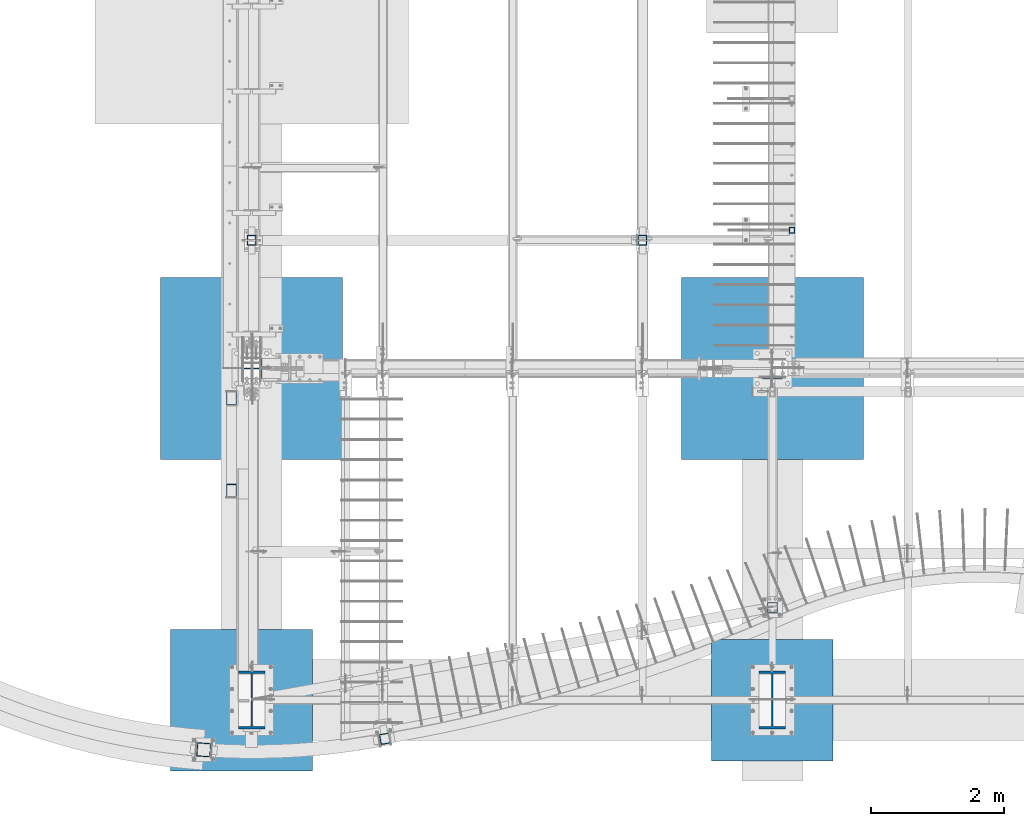
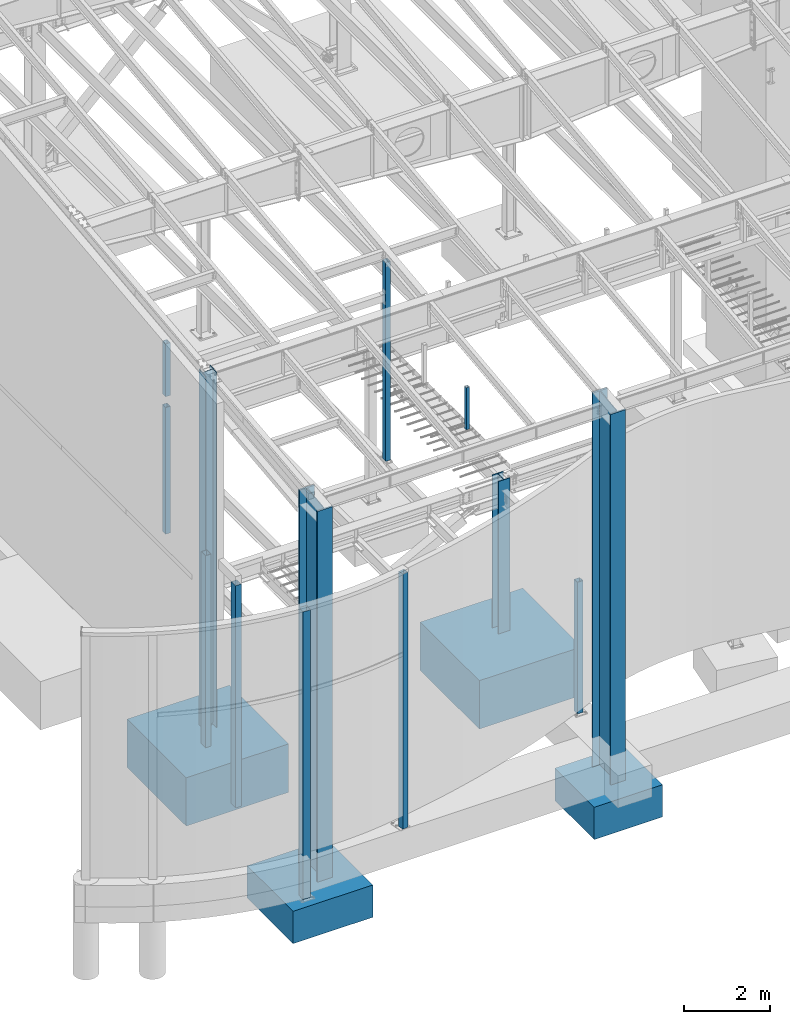
# One storey, part 351 of 1179: 17 columns, 17 elements without a shape of their own.
"""IFC2X3 building model written with IfcOpenShell, lengths in millimetres."""

from ifc_helpers import new_model, si_unit, frame, origin_with_axes, place, context, subcontext, project, spatial, faceted_brep, material, type_object, element, aggregate, save


model = new_model("IFC2X3")

# Units and contexts
model_context = context("Model", 3, precision=1e-05, world=origin_with_axes())
body_context = subcontext(model_context, "Body", "Model", "MODEL_VIEW")
ifc_project = project(units=[si_unit("LENGTHUNIT", "METRE", prefix="MILLI"), si_unit("AREAUNIT", "SQUARE_METRE"), si_unit("VOLUMEUNIT", "CUBIC_METRE"), si_unit("MASSUNIT", "GRAM", prefix="KILO"), si_unit("TIMEUNIT", "SECOND"), si_unit("PLANEANGLEUNIT", "RADIAN"), si_unit("SOLIDANGLEUNIT", "STERADIAN"), si_unit("THERMODYNAMICTEMPERATUREUNIT", "DEGREE_CELSIUS"), si_unit("LUMINOUSINTENSITYUNIT", "LUMEN")], contexts=[model_context])

# Site, building, storey
site_placement = place(None, origin_with_axes())
site = spatial("IfcSite", under=ifc_project, at=site_placement, CompositionType="ELEMENT")
building_placement = place(site_placement, origin_with_axes())
building = spatial("IfcBuilding", under=site, at=building_placement, Name="Undefined", CompositionType="ELEMENT")
storey_placement = place(building_placement, origin_with_axes())
storey = spatial("IfcBuildingStorey", under=building, at=storey_placement, Name="Undefined", CompositionType="ELEMENT", Elevation=0.0)

# Assembly, column
assembly_1_placement = place(storey_placement, origin_with_axes())
assembly_1 = element("IfcElementAssembly", 1, at=assembly_1_placement, inside=storey, Name="COLUMN", AssemblyPlace="NOTDEFINED", PredefinedType="RIGID_FRAME")
ifc_material_1 = material()
column_type_1 = type_object("IfcColumnType", Name="HSS6X6X3/8", PredefinedType="NOTDEFINED")
column_1_placement = place(assembly_1_placement, frame((8280.4000000008, 1835.06494231478, -431.8), z_axis=(0.0, 1.0, 0.0), x_axis=(0.0, 0.0, 1.0)))
column_1 = element("IfcColumn", 2, at=column_1_placement, type_object=column_type_1, material=ifc_material_1, Name="COLUMN", ObjectType="HSS6X6X3/8", context=body_context, shape_type="Brep", body=[
    faceted_brep([(76.2000000000008, 66.675000000112, -66.6749999999902), (76.2000000000008, -66.6750000001084, -66.6750000000175), (3803.64999993333, -66.6749999999993, -66.67500000004), (3803.64999993333, 66.6749999999993, -66.67500000004), (76.2000000000008, -66.6750000001011, 66.674999999992), (3803.65000006668, -66.6749999999993, 66.6749999999599), (76.2000000000008, 66.6750000001193, 66.6750000000193), (3803.65000006668, 66.6749999999993, 66.6749999999599), (76.2000000000008, 76.2000000001281, -76.1999999999898), (76.2000000000008, 76.2000000001317, 76.2000000000216), (3803.6500000762, 76.2000000000007, 76.19999999996), (3803.6499999238, 76.2000000000007, -76.2000000000401), (76.2000000000008, -76.2000000001171, 76.1999999999916), (3803.6500000762, -76.2000000000007, 76.19999999996), (76.2000000000008, -76.2000000001208, -76.2000000000198), (3803.6499999238, -76.2000000000007, -76.2000000000401)], [[[0, 1, 2, 3]], [[1, 4, 5, 2]], [[4, 6, 7, 5]], [[6, 0, 3, 7]], [[8, 9, 10, 11]], [[9, 12, 13, 10]], [[12, 14, 15, 13]], [[14, 8, 11, 15]], [[13, 15, 11, 10], [5, 7, 3, 2]], [[14, 12, 9, 8], [6, 4, 1, 0]]]),
])
aggregate(assembly_1, [column_1])

assembly_2_placement = place(storey_placement, origin_with_axes())
assembly_2 = element("IfcElementAssembly", 3, at=assembly_2_placement, inside=storey, Name="COLUMN", AssemblyPlace="NOTDEFINED", PredefinedType="RIGID_FRAME")
column_type_2 = type_object("IfcColumnType", Name="HSS6X5X5/16", PredefinedType="NOTDEFINED")
column_2_placement = place(assembly_2_placement, frame((432.344791494267, 7366.0, 8013.7), z_axis=(0.0, 1.0, 0.0), x_axis=(0.0, 0.0, 1.0)))
column_2 = element("IfcColumn", 4, at=column_2_placement, type_object=column_type_2, material=ifc_material_1, Name="COLUMN", ObjectType="HSS6X5X5/16", context=body_context, shape_type="Brep", body=[
    faceted_brep([(0.0, 55.5625, -68.2624999999998), (0.0, -55.5625, -68.2624999999998), (1494.56160031085, -55.5625, -68.2624999999998), (1494.56160031085, 55.5625, -68.2624999999998), (0.0, -55.5625, 68.2624999999998), (1494.56160031085, -55.5625, 68.2624999999998), (0.0, 55.5625, 68.2624999999998), (1494.56160031085, 55.5625, 68.2624999999998), (0.0, 63.5, -76.1999999999998), (0.0, 63.5, 76.1999999999998), (1494.56160031085, 63.5, 76.1999999999998), (1494.56160031085, 63.5, -76.1999999999998), (0.0, -63.5, 76.1999999999998), (1494.56160031085, -63.5, 76.1999999999998), (0.0, -63.5, -76.1999999999998), (1494.56160031085, -63.5, -76.1999999999998)], [[[0, 1, 2, 3]], [[1, 4, 5, 2]], [[4, 6, 7, 5]], [[6, 0, 3, 7]], [[8, 9, 10, 11]], [[9, 12, 13, 10]], [[12, 14, 15, 13]], [[14, 8, 11, 15]], [[13, 15, 11, 10], [5, 7, 3, 2]], [[14, 12, 9, 8], [6, 4, 1, 0]]]),
])
aggregate(assembly_2, [column_2])

assembly_3_placement = place(storey_placement, origin_with_axes())
assembly_3 = element("IfcElementAssembly", 5, at=assembly_3_placement, inside=storey, Name="COLUMN", AssemblyPlace="NOTDEFINED", PredefinedType="RIGID_FRAME")
column_3_placement = place(assembly_3_placement, frame((6324.59996446262, 7366.0, 4102.1), z_axis=(0.0, 1.0, 0.0), x_axis=(0.0, 0.0, 1.0)))
column_3 = element("IfcColumn", 6, at=column_3_placement, type_object=column_type_2, material=ifc_material_1, Name="COLUMN", ObjectType="HSS6X5X5/16", context=body_context, shape_type="Brep", body=[
    faceted_brep([(19.0500000000002, 55.5625, -68.2624999999998), (19.0500000000002, -55.5625, -68.2624999999998), (5645.80205145567, -55.5625, -68.2624999999998), (5645.80205145567, 55.5625, -68.2624999999998), (19.0500000000002, -55.5625, 68.2624999999998), (5645.80205145567, -55.5625, 68.2624999999998), (19.0500000000002, 55.5625, 68.2624999999998), (5645.80205145567, 55.5625, 68.2624999999998), (19.0500000000002, 63.5, -76.1999999999998), (19.0500000000002, 63.5, 76.1999999999998), (5645.80205145567, 63.5, 76.1999999999998), (5645.80205145567, 63.5, -76.1999999999998), (19.0500000000002, -63.5, 76.1999999999998), (5645.80205145567, -63.5, 76.1999999999998), (19.0500000000002, -63.5, -76.1999999999998), (5645.80205145567, -63.5, -76.1999999999998)], [[[0, 1, 2, 3]], [[1, 4, 5, 2]], [[4, 6, 7, 5]], [[6, 0, 3, 7]], [[8, 9, 10, 11]], [[9, 12, 13, 10]], [[12, 14, 15, 13]], [[14, 8, 11, 15]], [[13, 15, 11, 10], [5, 7, 3, 2]], [[14, 12, 9, 8], [6, 4, 1, 0]]]),
])
aggregate(assembly_3, [column_3])

assembly_4_placement = place(storey_placement, origin_with_axes())
assembly_4 = element("IfcElementAssembly", 7, at=assembly_4_placement, inside=storey, Name="COLUMN", AssemblyPlace="NOTDEFINED", PredefinedType="RIGID_FRAME")
column_4_placement = place(assembly_4_placement, frame((432.344791494267, 7366.0, 4102.1), z_axis=(0.0, 1.0, 0.0), x_axis=(0.0, 0.0, 1.0)))
column_4 = element("IfcColumn", 8, at=column_4_placement, type_object=column_type_2, material=ifc_material_1, Name="COLUMN", ObjectType="HSS6X5X5/16", context=body_context, shape_type="Brep", body=[
    faceted_brep([(19.0500000000002, 55.5625, -68.2624999999998), (19.0500000000002, -55.5625, -68.2624999999998), (3606.8, -55.5625, -68.2624999999998), (3606.8, 55.5625, -68.2624999999998), (19.0500000000002, -55.5625, 68.2624999999998), (3606.8, -55.5625, 68.2624999999998), (19.0500000000002, 55.5625, 68.2624999999998), (3606.8, 55.5625, 68.2624999999998), (19.0500000000002, 63.5, -76.1999999999998), (19.0500000000002, 63.5, 76.1999999999998), (3606.8, 63.5, 76.1999999999998), (3606.8, 63.5, -76.1999999999998), (19.0500000000002, -63.5, 76.1999999999998), (3606.8, -63.5, 76.1999999999998), (19.0500000000002, -63.5, -76.1999999999998), (3606.8, -63.5, -76.1999999999998)], [[[0, 1, 2, 3]], [[1, 4, 5, 2]], [[4, 6, 7, 5]], [[6, 0, 3, 7]], [[8, 9, 10, 11]], [[9, 12, 13, 10]], [[12, 14, 15, 13]], [[14, 8, 11, 15]], [[13, 15, 11, 10], [5, 7, 3, 2]], [[14, 12, 9, 8], [6, 4, 1, 0]]]),
])
aggregate(assembly_4, [column_4])

assembly_5_placement = place(storey_placement, origin_with_axes())
assembly_5 = element("IfcElementAssembly", 9, at=assembly_5_placement, inside=storey, Name="COLUMN", AssemblyPlace="NOTDEFINED", PredefinedType="RIGID_FRAME")
column_type_3 = type_object("IfcColumnType", Name="HSS6X6X1/4", PredefinedType="NOTDEFINED")
column_5_placement = place(assembly_5_placement, frame((2444.75, -144.4625, -431.8), z_axis=(-0.169391131050126, 0.985548905291645, 0.0), x_axis=(0.0, 0.0, 1.0)))
column_5 = element("IfcColumn", 10, at=column_5_placement, type_object=column_type_3, material=ifc_material_1, Name="COLUMN", ObjectType="HSS6X6X1/4", context=body_context, shape_type="Brep", body=[
    faceted_brep([(57.15, 69.8499999999804, -69.8499999999957), (57.15, -69.8500000000104, -69.8499999999983), (7283.45, -69.8500000000104, -69.8499999999983), (7283.45, 69.8499999999804, -69.8499999999957), (57.15, -69.8499999999808, 69.8499999999956), (7283.45, -69.8499999999808, 69.8499999999956), (57.15, 69.8500000000104, 69.8499999999981), (7283.45, 69.8500000000104, 69.8499999999981), (57.15, 76.1999999999789, -76.1999999999953), (57.15, 76.2000000000112, 76.1999999999979), (7283.45, 76.2000000000112, 76.1999999999979), (7283.45, 76.1999999999789, -76.1999999999953), (57.15, -76.1999999999789, 76.1999999999952), (7283.45, -76.1999999999789, 76.1999999999952), (57.15, -76.2000000000116, -76.199999999998), (7283.45, -76.2000000000116, -76.199999999998)], [[[0, 1, 2, 3]], [[1, 4, 5, 2]], [[4, 6, 7, 5]], [[6, 0, 3, 7]], [[8, 9, 10, 11]], [[9, 12, 13, 10]], [[12, 14, 15, 13]], [[14, 8, 11, 15]], [[13, 15, 11, 10], [5, 7, 3, 2]], [[14, 12, 9, 8], [6, 4, 1, 0]]]),
])
aggregate(assembly_5, [column_5])

assembly_6_placement = place(storey_placement, origin_with_axes())
assembly_6 = element("IfcElementAssembly", 11, at=assembly_6_placement, inside=storey, Name="COLUMN", AssemblyPlace="NOTDEFINED", PredefinedType="RIGID_FRAME")
column_type_4 = type_object("IfcColumnType", Name="HSS3-1/2X3-1/2X5/16", PredefinedType="NOTDEFINED")
column_6_placement = place(assembly_6_placement, frame((8575.675, 7518.40000000001, 4108.45), z_axis=(0.0, 1.0, 0.0), x_axis=(0.0, 0.0, 1.0)))
column_6 = element("IfcColumn", 12, at=column_6_placement, type_object=column_type_4, material=ifc_material_1, Name="COLUMN", ObjectType="HSS3-1/2X3-1/2X5/16", context=body_context, shape_type="Brep", body=[
    faceted_brep([(0.0, 36.5125000000007, -36.5125000000007), (0.0, -36.5125000000007, -36.5125000000007), (1189.03749999998, -36.5125000000007, -36.5124999999998), (1189.03749999998, 36.5125000000007, -36.5124999999998), (0.0, -36.5125000000007, 36.5125000000007), (1189.03749999998, -36.5125000000007, 36.5124999999998), (0.0, 36.5125000000007, 36.5125000000007), (1189.03749999998, 36.5125000000007, 36.5124999999998), (0.0, 44.4500000000007, -44.4499999999998), (0.0, 44.4500000000007, 44.4500000000007), (1189.03749999998, 44.4500000000007, 44.4499999999998), (1189.03749999998, 44.4500000000007, -44.4499999999998), (0.0, -44.4500000000007, 44.4500000000007), (1189.03749999998, -44.4500000000007, 44.4499999999998), (0.0, -44.4500000000007, -44.4500000000007), (1189.03749999998, -44.4500000000007, -44.4499999999998)], [[[0, 1, 2, 3]], [[1, 4, 5, 2]], [[4, 6, 7, 5]], [[6, 0, 3, 7]], [[8, 9, 10, 11]], [[9, 12, 13, 10]], [[12, 14, 15, 13]], [[14, 8, 11, 15]], [[13, 15, 11, 10], [5, 7, 3, 2]], [[14, 12, 9, 8], [6, 4, 1, 0]]]),
])
aggregate(assembly_6, [column_6])

assembly_7_placement = place(storey_placement, origin_with_axes())
assembly_7 = element("IfcElementAssembly", 13, at=assembly_7_placement, inside=storey, Name="COLUMN", AssemblyPlace="NOTDEFINED", PredefinedType="RIGID_FRAME")
column_type_5 = type_object("IfcColumnType", Name="HSS8X6X3/8", PredefinedType="NOTDEFINED")
column_7_placement = place(assembly_7_placement, frame((127.0, 3590.925, -1219.2), z_axis=(0.0, 1.0, 0.0), x_axis=(0.0, 0.0, 1.0)))
column_7 = element("IfcColumn", 14, at=column_7_placement, type_object=column_type_5, material=ifc_material_1, Name="COLUMN", ObjectType="HSS8X6X3/8", context=body_context, shape_type="Brep", body=[
    faceted_brep([(9.52500000000009, -66.67500038147, -101.6), (19.0499996185301, -76.2, -101.6), (19.0499996185301, -76.2, 101.6), (9.52500000000009, -66.67500038147, 101.6), (9.52500000002851, 66.6750000000029, -92.0750000000025), (9.52500000002851, -66.6750000000029, -92.0750000000025), (6299.2, -66.675, -92.0749999999998), (6299.2, 66.675, -92.0749999999998), (9.52499999997079, -66.6750000000029, 92.074999999998), (6299.2, -66.675, 92.0749999999998), (9.52499999997079, 66.6750000000029, 92.074999999998), (6299.2, 66.675, 92.0749999999998), (9.52500000003153, 76.1999999999971, -101.600000000002), (9.52499999996778, 76.1999999999971, 101.599999999998), (6299.2, 76.2, 101.6), (6299.2, 76.2, -101.6), (6299.2, -76.2, 101.6), (6299.2, -76.2, -101.6)], [[[0, 1, 2, 3]], [[4, 5, 6, 7]], [[5, 8, 9, 6]], [[8, 10, 11, 9]], [[10, 4, 7, 11]], [[12, 13, 14, 15]], [[16, 14, 13, 3, 2]], [[17, 16, 2, 1]], [[12, 15, 17, 1, 0]], [[16, 17, 15, 14], [9, 11, 7, 6]], [[13, 12, 0, 3], [10, 8, 5, 4]]]),
])
aggregate(assembly_7, [column_7])

assembly_8_placement = place(storey_placement, origin_with_axes())
assembly_8 = element("IfcElementAssembly", 15, at=assembly_8_placement, inside=storey, Name="COLUMN", AssemblyPlace="NOTDEFINED", PredefinedType="RIGID_FRAME")
column_8_placement = place(assembly_8_placement, frame((127.0, 4987.925, -1219.2), z_axis=(0.0, 1.0, 0.0), x_axis=(0.0, 0.0, 1.0)))
column_8 = element("IfcColumn", 16, at=column_8_placement, type_object=column_type_5, material=ifc_material_1, Name="COLUMN", ObjectType="HSS8X6X3/8", context=body_context, shape_type="Brep", body=[
    faceted_brep([(9.52500000000009, -66.67500038147, -101.6), (19.0499996185301, -76.2, -101.6), (19.0499996185301, -76.2, 101.6), (9.52500000000009, -66.67500038147, 101.6), (9.52500000002851, 66.6750000000029, -92.0750000000025), (9.52500000002851, -66.6750000000029, -92.0750000000025), (6299.2, -66.675, -92.0749999999998), (6299.2, 66.675, -92.0749999999998), (9.52499999997079, -66.6750000000029, 92.074999999998), (6299.2, -66.675, 92.0749999999998), (9.52499999997079, 66.6750000000029, 92.074999999998), (6299.2, 66.675, 92.0749999999998), (9.52500000003153, 76.1999999999971, -101.600000000002), (9.52499999996778, 76.1999999999971, 101.599999999998), (6299.2, 76.2, 101.6), (6299.2, 76.2, -101.6), (6299.2, -76.2, 101.6), (6299.2, -76.2, -101.6)], [[[0, 1, 2, 3]], [[4, 5, 6, 7]], [[5, 8, 9, 6]], [[8, 10, 11, 9]], [[10, 4, 7, 11]], [[12, 13, 14, 15]], [[16, 14, 13, 3, 2]], [[17, 16, 2, 1]], [[12, 15, 17, 1, 0]], [[16, 17, 15, 14], [9, 11, 7, 6]], [[13, 12, 0, 3], [10, 8, 5, 4]]]),
])
aggregate(assembly_8, [column_8])

assembly_9_placement = place(storey_placement, origin_with_axes())
assembly_9 = element("IfcElementAssembly", 17, at=assembly_9_placement, inside=storey, Name="COLUMN", AssemblyPlace="NOTDEFINED", PredefinedType="RIGID_FRAME")
column_type_6 = type_object("IfcColumnType", Name="HSS8X8X1/4", PredefinedType="NOTDEFINED")
column_9_placement = place(assembly_9_placement, frame((-288.925, -311.15, -1346.2), z_axis=(0.0697564740168352, 0.997564050240755, 0.0), x_axis=(0.0, 0.0, 1.0)))
column_9 = element("IfcColumn", 18, at=column_9_placement, type_object=column_type_6, material=ifc_material_1, Name="COLUMN", ObjectType="HSS8X8X1/4", context=body_context, shape_type="Brep", body=[
    faceted_brep([(57.1500000000001, 95.2500000000011, -95.2500000000046), (57.1500000000001, -95.2500000000046, -95.250000000001), (8204.2, -95.2500000000046, -95.250000000001), (8204.2, 95.2500000000011, -95.2500000000046), (57.1500000000001, -95.250000000001, 95.2500000000046), (8204.2, -95.250000000001, 95.2500000000046), (57.1500000000001, 95.2500000000046, 95.250000000001), (8204.2, 95.2500000000046, 95.250000000001), (57.1500000000001, 101.600000000001, -101.600000000005), (57.1500000000001, 101.600000000005, 101.600000000001), (8204.2, 101.600000000005, 101.600000000001), (8204.2, 101.600000000001, -101.600000000005), (57.1500000000001, -101.600000000001, 101.600000000005), (8204.2, -101.600000000001, 101.600000000005), (57.1500000000001, -101.600000000005, -101.600000000001), (8204.2, -101.600000000005, -101.600000000001)], [[[0, 1, 2, 3]], [[1, 4, 5, 2]], [[4, 6, 7, 5]], [[6, 0, 3, 7]], [[8, 9, 10, 11]], [[9, 12, 13, 10]], [[12, 14, 15, 13]], [[14, 8, 11, 15]], [[13, 15, 11, 10], [5, 7, 3, 2]], [[14, 12, 9, 8], [6, 4, 1, 0]]]),
])
aggregate(assembly_9, [column_9])

assembly_10_placement = place(storey_placement, origin_with_axes())
assembly_10 = element("IfcElementAssembly", 19, at=assembly_10_placement, inside=storey, Name="FOOTING", AssemblyPlace="NOTDEFINED", PredefinedType="REINFORCEMENT_UNIT")
ifc_material_2 = material(Name="CONCRETE/3000")
column_type_7 = type_object("IfcColumnType", PredefinedType="NOTDEFINED")
column_10_placement = place(assembly_10_placement, frame((8280.4, 438.15, -2260.6), z_axis=(-1.0, 0.0, 0.0), x_axis=(0.0, 0.0, 1.0)))
column_10 = element("IfcColumn", 20, at=column_10_placement, type_object=column_type_7, material=ifc_material_2, Name="FOOTING", context=body_context, shape_type="Brep", body=[
    faceted_brep([(0.0, 914.400000000001, -914.400000000001), (0.0, 914.400000000001, 914.400000000001), (914.4, 914.4, 914.400000000001), (914.4, 914.4, -914.400000000001), (0.0, -914.400000000001, 914.400000000001), (914.4, -914.4, 914.400000000001), (0.0, -914.400000000001, -914.400000000001), (914.4, -914.4, -914.400000000001)], [[[0, 1, 2, 3]], [[1, 4, 5, 2]], [[4, 6, 7, 5]], [[6, 0, 3, 7]], [[5, 7, 3, 2]], [[6, 4, 1, 0]]]),
])
aggregate(assembly_10, [column_10])

assembly_11_placement = place(storey_placement, origin_with_axes())
assembly_11 = element("IfcElementAssembly", 21, at=assembly_11_placement, inside=storey, Name="FOOTING", AssemblyPlace="NOTDEFINED", PredefinedType="REINFORCEMENT_UNIT")
column_type_8 = type_object("IfcColumnType", PredefinedType="NOTDEFINED")
column_11_placement = place(assembly_11_placement, frame((279.400000000002, 438.15, -2260.6), z_axis=(-1.0, 0.0, 0.0), x_axis=(0.0, 0.0, 1.0)))
column_11 = element("IfcColumn", 22, at=column_11_placement, type_object=column_type_8, material=ifc_material_2, Name="FOOTING", context=body_context, shape_type="Brep", body=[
    faceted_brep([(0.0, 1066.8, -1066.8), (0.0, 1066.8, 1066.8), (914.400000000001, 1066.8, 1066.8), (914.400000000001, 1066.8, -1066.8), (0.0, -1066.8, 1066.8), (914.400000000001, -1066.8, 1066.8), (0.0, -1066.8, -1066.8), (914.400000000001, -1066.8, -1066.8)], [[[0, 1, 2, 3]], [[1, 4, 5, 2]], [[4, 6, 7, 5]], [[6, 0, 3, 7]], [[5, 7, 3, 2]], [[6, 4, 1, 0]]]),
])
aggregate(assembly_11, [column_11])

assembly_12_placement = place(storey_placement, origin_with_axes())
assembly_12 = element("IfcElementAssembly", 23, at=assembly_12_placement, inside=storey, Name="FOOTING", AssemblyPlace="NOTDEFINED", PredefinedType="REINFORCEMENT_UNIT")
column_type_9 = type_object("IfcColumnType", PredefinedType="NOTDEFINED")
column_12_placement = place(assembly_12_placement, frame((8280.4, 5435.6, -1727.2), z_axis=(-1.0, 0.0, 0.0), x_axis=(0.0, 0.0, 1.0)))
column_12 = element("IfcColumn", 24, at=column_12_placement, type_object=column_type_9, material=ifc_material_2, Name="FOOTING", context=body_context, shape_type="Brep", body=[
    faceted_brep([(0.0, 1371.6, -1371.6), (0.0, 1371.6, 1371.6), (1371.6, 1371.6, 1371.6), (1371.6, 1371.6, -1371.6), (0.0, -1371.6, 1371.6), (1371.6, -1371.6, 1371.6), (0.0, -1371.6, -1371.6), (1371.6, -1371.6, -1371.6)], [[[0, 1, 2, 3]], [[1, 4, 5, 2]], [[4, 6, 7, 5]], [[6, 0, 3, 7]], [[5, 7, 3, 2]], [[6, 4, 1, 0]]]),
])
aggregate(assembly_12, [column_12])

assembly_13_placement = place(storey_placement, origin_with_axes())
assembly_13 = element("IfcElementAssembly", 25, at=assembly_13_placement, inside=storey, Name="FOOTING", AssemblyPlace="NOTDEFINED", PredefinedType="REINFORCEMENT_UNIT")
column_13_placement = place(assembly_13_placement, frame((431.800000000002, 5435.6, -1727.2), z_axis=(-1.0, 0.0, 0.0), x_axis=(0.0, 0.0, 1.0)))
column_13 = element("IfcColumn", 26, at=column_13_placement, type_object=column_type_9, material=ifc_material_2, Name="FOOTING", context=body_context, shape_type="Brep", body=[
    faceted_brep([(0.0, 1371.6, -1371.6), (0.0, 1371.6, 1371.6), (1371.6, 1371.6, 1371.6), (1371.6, 1371.6, -1371.6), (0.0, -1371.6, 1371.6), (1371.6, -1371.6, 1371.6), (0.0, -1371.6, -1371.6), (1371.6, -1371.6, -1371.6)], [[[0, 1, 2, 3]], [[1, 4, 5, 2]], [[4, 6, 7, 5]], [[6, 0, 3, 7]], [[5, 7, 3, 2]], [[6, 4, 1, 0]]]),
])
aggregate(assembly_13, [column_13])

assembly_14_placement = place(storey_placement, origin_with_axes())
assembly_14 = element("IfcElementAssembly", 27, at=assembly_14_placement, inside=storey, Name="COLUMN", AssemblyPlace="NOTDEFINED", PredefinedType="RIGID_FRAME")
ifc_material_3 = material(Name="STEEL/A992")
column_type_10 = type_object("IfcColumnType", Name="W33X263", PredefinedType="NOTDEFINED")
column_14_placement = place(assembly_14_placement, frame((8280.4, 438.15, -1346.2), z_axis=(0.0, 1.0, 0.0), x_axis=(0.0, 0.0, 1.0)))
column_14 = element("IfcColumn", 28, at=column_14_placement, type_object=column_type_10, material=ifc_material_3, Name="COLUMN", ObjectType="W33X263", context=body_context, shape_type="Brep", body=[
    faceted_brep([(88.8999999999999, 200.025000000001, -438.15), (88.8999999999999, 200.025000000001, -398.4625), (10587.9886488325, 200.025000000001, -398.4625), (10583.5040139534, 200.025000000001, -438.15), (88.8999999999999, 11.1124999999993, -398.4625), (10587.9886488325, 11.1124999999993, -398.4625), (88.8999999999999, 11.1124999999993, 398.4625), (10678.0401172034, 11.1124999999993, 398.4625), (88.8999999999999, 200.025000000001, 398.4625), (10678.0401172034, 200.025000000001, 398.4625), (88.8999999999999, 200.025000000001, 438.15), (10682.5247520824, 200.025000000001, 438.15), (88.8999999999999, -200.025000000001, 438.15), (10682.5247520824, -200.025000000001, 438.15), (88.8999999999999, -200.025000000001, 398.4625), (10678.0401172034, -200.025000000001, 398.4625), (88.8999999999999, -11.1124999999993, 398.4625), (10678.0401172034, -11.1124999999993, 398.4625), (88.8999999999999, -11.1124999999993, -398.4625), (10587.9886488325, -11.1124999999993, -398.4625), (88.8999999999999, -200.025000000001, -398.4625), (10587.9886488325, -200.025000000001, -398.4625), (88.8999999999999, -200.025000000001, -438.15), (10583.5040139534, -200.025000000001, -438.15)], [[[0, 1, 2, 3]], [[1, 4, 5, 2]], [[4, 6, 7, 5]], [[6, 8, 9, 7]], [[8, 10, 11, 9]], [[10, 12, 13, 11]], [[12, 14, 15, 13]], [[14, 16, 17, 15]], [[16, 18, 19, 17]], [[18, 20, 21, 19]], [[20, 22, 23, 21]], [[22, 0, 3, 23]], [[5, 7, 9, 11, 13, 15, 17, 19, 21, 23, 3, 2]], [[22, 20, 18, 16, 14, 12, 10, 8, 6, 4, 1, 0]]]),
])
aggregate(assembly_14, [column_14])

assembly_15_placement = place(storey_placement, origin_with_axes())
assembly_15 = element("IfcElementAssembly", 29, at=assembly_15_placement, inside=storey, Name="COLUMN", AssemblyPlace="NOTDEFINED", PredefinedType="RIGID_FRAME")
column_15_placement = place(assembly_15_placement, frame((431.800000000002, 438.15, -1346.2), z_axis=(0.0, 1.0, 0.0), x_axis=(0.0, 0.0, 1.0)))
column_15 = element("IfcColumn", 30, at=column_15_placement, type_object=column_type_10, material=ifc_material_3, Name="COLUMN", ObjectType="W33X263", context=body_context, shape_type="Brep", body=[
    faceted_brep([(88.8999999999999, 200.025000000001, -438.15), (88.8999999999999, 200.025000000001, -398.4625), (10587.9886488325, 200.025000000001, -398.4625), (10583.5040139534, 200.025000000001, -438.15), (88.8999999999999, 11.1124999999993, -398.4625), (10587.9886488325, 11.1124999999993, -398.4625), (88.8999999999999, 11.1124999999993, 398.4625), (10678.0401172034, 11.1124999999993, 398.4625), (88.8999999999999, 200.025000000001, 398.4625), (10678.0401172034, 200.025000000001, 398.4625), (88.8999999999999, 200.025000000001, 438.15), (10682.5247520824, 200.025000000001, 438.15), (88.8999999999999, -200.025000000001, 438.15), (10682.5247520824, -200.025000000001, 438.15), (88.8999999999999, -200.025000000001, 398.4625), (10678.0401172034, -200.025000000001, 398.4625), (88.8999999999999, -11.1124999999993, 398.4625), (10678.0401172034, -11.1124999999993, 398.4625), (88.8999999999999, -11.1124999999993, -398.4625), (10587.9886488325, -11.1124999999993, -398.4625), (88.8999999999999, -200.025000000001, -398.4625), (10587.9886488325, -200.025000000001, -398.4625), (88.8999999999999, -200.025000000001, -438.15), (10583.5040139534, -200.025000000001, -438.15)], [[[0, 1, 2, 3]], [[1, 4, 5, 2]], [[4, 6, 7, 5]], [[6, 8, 9, 7]], [[8, 10, 11, 9]], [[10, 12, 13, 11]], [[12, 14, 15, 13]], [[14, 16, 17, 15]], [[16, 18, 19, 17]], [[18, 20, 21, 19]], [[20, 22, 23, 21]], [[22, 0, 3, 23]], [[5, 7, 9, 11, 13, 15, 17, 19, 21, 23, 3, 2]], [[22, 20, 18, 16, 14, 12, 10, 8, 6, 4, 1, 0]]]),
])
aggregate(assembly_15, [column_15])

assembly_16_placement = place(storey_placement, origin_with_axes())
assembly_16 = element("IfcElementAssembly", 31, at=assembly_16_placement, inside=storey, Name="COLUMN", AssemblyPlace="NOTDEFINED", PredefinedType="RIGID_FRAME")
column_type_11 = type_object("IfcColumnType", Name="W12X72", PredefinedType="NOTDEFINED")
column_16_placement = place(assembly_16_placement, frame((8280.4, 5435.6, -355.6), z_axis=(0.0, 0.999999999997826, -2.0849999999939e-06), x_axis=(0.0, 1.69599999891578e-06, 0.999999999998562)))
column_16 = element("IfcColumn", 32, at=column_16_placement, type_object=column_type_11, material=ifc_material_3, Name="COLUMN", ObjectType="W12X72", context=body_context, shape_type="Brep", body=[
    faceted_brep([(159.306912799359, -152.4, 155.575000000092), (159.306912799359, 152.4, 155.575000000092), (149.224997117765, 152.4, 138.112500000083), (149.224997117765, 5.55624999999964, 138.112500000083), (148.995790502264, 5.55624999999964, 137.715500000322), (148.995790502262, -5.55625008999777, 137.715500000319), (149.224821354481, -5.55625009190044, 138.112195567232), (149.224997117765, -152.4, 138.112500000083), (4476.75032578374, 152.4, -155.574999999013), (4476.75032578374, -152.4, -155.574999999013), (159.306305257642, -152.4, -155.575000000019), (159.306305257642, 152.4, -155.575000000019), (4476.75032578374, -152.4, -138.112499999006), (149.225368710553, -152.4, -138.112500000015), (4476.75032578374, -5.55624999999964, -138.112499999006), (149.225368710553, -5.55624999999964, -138.112500000015), (187.325287137352, -5.55625006556329, 137.715500000309), (187.325287137352, 5.55624999999964, 137.715500000309), (206.902936152913, 5.55624999999964, 131.287140466046), (206.902936152913, -5.55625006427726, 131.287140466046), (211.285648456011, 5.55624999999964, 128.290735053231), (211.285648456011, -5.55625006372975, 128.290735053231), (213.38356603631, 5.55624999999964, 123.413711949332), (213.38356603631, -5.55625006289483, 123.413711949332), (212.544908377651, 5.55624999999964, 118.171263488804), (212.544908377651, -5.55625006203081, 118.171263488804), (209.030229434475, 5.55624999999964, 114.192112265727), (209.030229434475, -5.5562500614069, 114.192112265727), (203.931468793561, 5.55624999999964, 112.712500000182), (203.931468793561, -5.55625006121591, 112.712500000182), (139.700235005896, 5.55624999999964, 112.712500000182), (146.115965264539, -5.55625008350944, 112.712500000182), (139.699764994719, 5.55624999999964, -112.71250000013), (146.115495252844, -5.55625000845612, -112.712500000131), (203.930921325824, 5.55624999999964, -112.712500000098), (203.930921325824, -5.55625002660599, -112.712500000098), (209.029682619756, 5.55624999999964, -114.192112679487), (209.029682619756, -5.55625002630586, -114.192112679487), (212.544361569998, 5.55624999999964, -118.171264886961), (212.544361569998, -5.55625002560555, -118.171264886961), (213.38301828216, 5.55624999999964, -123.413714250829), (213.38301828216, -5.55625002472334, -123.413714250829), (211.285099022978, 5.55624999999964, -128.290737440801), (211.285099022978, -5.5562500239339, -128.290737440801), (206.902385012513, 5.55624999999964, -131.287141671881), (206.902385012513, -5.55625002348279, -131.287141671881), (187.324712863505, 5.55624999999964, -137.715500000166), (187.324712863505, -5.55625002262059, -137.715500000166), (148.996184355117, 5.55624999999964, -137.715500000253), (148.996184355117, -5.55625000170403, -137.715500000253), (4476.75032578374, 5.55624999999964, -138.112499999006), (4476.75032578374, 152.4, -138.112499999006), (149.225368710553, 152.4, -138.112500000015), (149.225368710553, 5.55624999999964, -138.112500000015), (4476.75032578374, 5.55624999999964, 138.112500001091), (4476.75032578374, 152.4, 138.112500001091), (4476.75032578374, 152.4, 155.575000001098), (4476.75032578374, -152.4, 155.575000001098), (4476.75032578374, -152.4, 138.112500001091), (4476.75032578374, -5.55624999999964, 138.112500001091)], [[[0, 1, 2, 3, 4, 5, 6, 7]], [[8, 9, 10, 11]], [[9, 12, 13, 10]], [[12, 14, 15, 13]], [[16, 17, 18, 19]], [[19, 18, 20, 21]], [[21, 20, 22, 23]], [[23, 22, 24, 25]], [[25, 24, 26, 27]], [[27, 26, 28, 29]], [[29, 28, 30, 31]], [[32, 33, 31, 30]], [[33, 32, 34, 35]], [[35, 34, 36, 37]], [[37, 36, 38, 39]], [[39, 38, 40, 41]], [[41, 40, 42, 43]], [[43, 42, 44, 45]], [[45, 44, 46, 47]], [[47, 46, 48, 49]], [[50, 51, 52, 53]], [[10, 13, 15, 49, 48, 53, 52, 11]], [[51, 8, 11, 52]], [[50, 54, 55, 56, 57, 58, 59, 14, 12, 9, 8, 51]], [[58, 57, 0, 7]], [[59, 58, 7, 6]], [[16, 19, 21, 23, 25, 27, 29, 31, 33, 35, 37, 39, 41, 43, 45, 47, 49, 15, 14, 59, 6, 5]], [[17, 16, 5, 4]], [[54, 50, 53, 48, 46, 44, 42, 40, 38, 36, 34, 32, 30, 28, 26, 24, 22, 20, 18, 17, 4, 3]], [[55, 54, 3, 2]], [[56, 55, 2, 1]], [[57, 56, 1, 0]]]),
])
aggregate(assembly_16, [column_16])

assembly_17_placement = place(storey_placement, origin_with_axes())
assembly_17 = element("IfcElementAssembly", 33, at=assembly_17_placement, inside=storey, Name="COLUMN", AssemblyPlace="NOTDEFINED", PredefinedType="RIGID_FRAME")
column_17_placement = place(assembly_17_placement, frame((431.800000000002, 5435.6, -355.6), z_axis=(-1.0, 0.0, 0.0), x_axis=(0.0, 0.0, 1.0)))
column_17 = element("IfcColumn", 34, at=column_17_placement, type_object=column_type_11, material=ifc_material_3, Name="COLUMN", ObjectType="W12X72", context=body_context, shape_type="Brep", body=[
    faceted_brep([(159.306511203312, -152.400000000009, 155.575000000001), (159.306689511402, 152.400000000118, 155.575), (149.22507268317, 152.400000000115, 138.1125), (149.224997117765, 5.55624999999964, 138.112500000083), (148.995790502264, 5.55624999999964, 137.715500000322), (148.995780457263, -5.55638080643257, 137.7155), (149.22498027864, -5.5563836004294, 138.112500000002), (149.224894375079, -152.400000000012, 138.1125), (10233.9173168563, 152.400000003529, -155.575), (10199.4750394889, -152.39999999661, -155.575), (159.306643303939, -152.400000000009, -155.574999999998), (159.306592097424, 152.400000000118, -155.575), (10199.4750394889, -152.39999999661, -138.1125), (149.225368710553, -152.4, -138.112500000015), (10216.0683241581, -5.55624999654356, -138.1125), (149.225368710553, -5.55624999999964, -138.112500000015), (187.324998311037, -5.55634562956402, 137.7155), (187.32500168927, 5.55625000006603, 137.7155), (206.902662271354, 5.5562500000724, 131.287141068804), (206.902658893121, -5.55634393901073, 131.287141068804), (211.285375428136, 5.55625000007512, 128.290736246861), (211.285372049904, -5.55634318376997, 128.290736246861), (213.383293847878, 5.55625000007512, 123.41371309993), (213.383290469647, -5.55634198931057, 123.41371309993), (212.544636662468, 5.55625000007421, 118.171264187737), (212.544633284237, -5.55634072672456, 118.171264187737), (209.029957715759, 5.55625000007421, 114.192112472464), (209.029954337528, -5.55633978827427, 114.192112472464), (203.931196748336, 5.55625000007149, 112.7125), (203.931193370105, -5.55633946551552, 112.7125), (139.700005078478, 5.55625000004966, 112.7125), (146.115725180218, -5.55637135279903, 112.7125), (139.700005078478, 5.55625000004966, -112.712500733316), (146.115725180219, -5.5562622888483, -112.71249926646), (203.931196287186, 5.5562500000724, -112.712500733407), (203.931193831311, -5.55628917117247, -112.712499266553), (209.02995725461, 5.55625000007331, -114.192113205872), (209.029954798735, -5.55628877940671, -114.192111739017), (212.544636201319, 5.55625000007512, -118.171264921146), (212.544633745444, -5.55628779349809, -118.171263454291), (213.383293386729, 5.55625000007512, -123.413713833339), (213.383290930854, -5.5562865197453, -123.413712366485), (211.285374966986, 5.55625000007421, -128.29073698027), (211.285372511112, -5.5562853538795, -128.290735513416), (206.902661810203, 5.55625000007331, -131.287141802213), (206.902659354329, -5.5562846581106, -131.287140335358), (187.325001228115, 5.55625000006694, -137.715500733408), (187.324998772241, -5.5562832329606, -137.715499266554), (148.996184355117, 5.55624999999964, -137.715500000253), (148.996184355117, -5.55625000170403, -137.715500000253), (10217.3240321871, 5.55625000346208, -138.1125), (10233.9173168563, 152.400000003529, -138.1125), (149.225368710553, 152.4, -138.112500000015), (149.225368710553, 5.55624999999964, -138.112500000015), (10217.3240321871, 5.55625000346208, 138.1125), (10233.9173168563, 152.400000003529, 138.1125), (10233.9173168563, 152.400000003529, 155.575), (10199.4750394889, -152.39999999661, 155.575), (10199.4750394889, -152.39999999661, 138.1125), (10216.0683241581, -5.55624999654356, 138.1125)], [[[0, 1, 2, 3, 4, 5, 6, 7]], [[8, 9, 10, 11]], [[9, 12, 13, 10]], [[12, 14, 15, 13]], [[16, 17, 18, 19]], [[19, 18, 20, 21]], [[21, 20, 22, 23]], [[23, 22, 24, 25]], [[25, 24, 26, 27]], [[27, 26, 28, 29]], [[29, 28, 30, 31]], [[32, 33, 31, 30]], [[33, 32, 34, 35]], [[35, 34, 36, 37]], [[37, 36, 38, 39]], [[39, 38, 40, 41]], [[41, 40, 42, 43]], [[43, 42, 44, 45]], [[45, 44, 46, 47]], [[47, 46, 48, 49]], [[50, 51, 52, 53]], [[10, 13, 15, 49, 48, 53, 52, 11]], [[51, 8, 11, 52]], [[50, 54, 55, 56, 57, 58, 59, 14, 12, 9, 8, 51]], [[58, 57, 0, 7]], [[59, 58, 7, 6]], [[16, 19, 21, 23, 25, 27, 29, 31, 33, 35, 37, 39, 41, 43, 45, 47, 49, 15, 14, 59, 6, 5]], [[17, 16, 5, 4]], [[54, 50, 53, 48, 46, 44, 42, 40, 38, 36, 34, 32, 30, 28, 26, 24, 22, 20, 18, 17, 4, 3]], [[55, 54, 3, 2]], [[56, 55, 2, 1]], [[57, 56, 1, 0]]]),
])
aggregate(assembly_17, [column_17])

save(model, "model.ifc")
